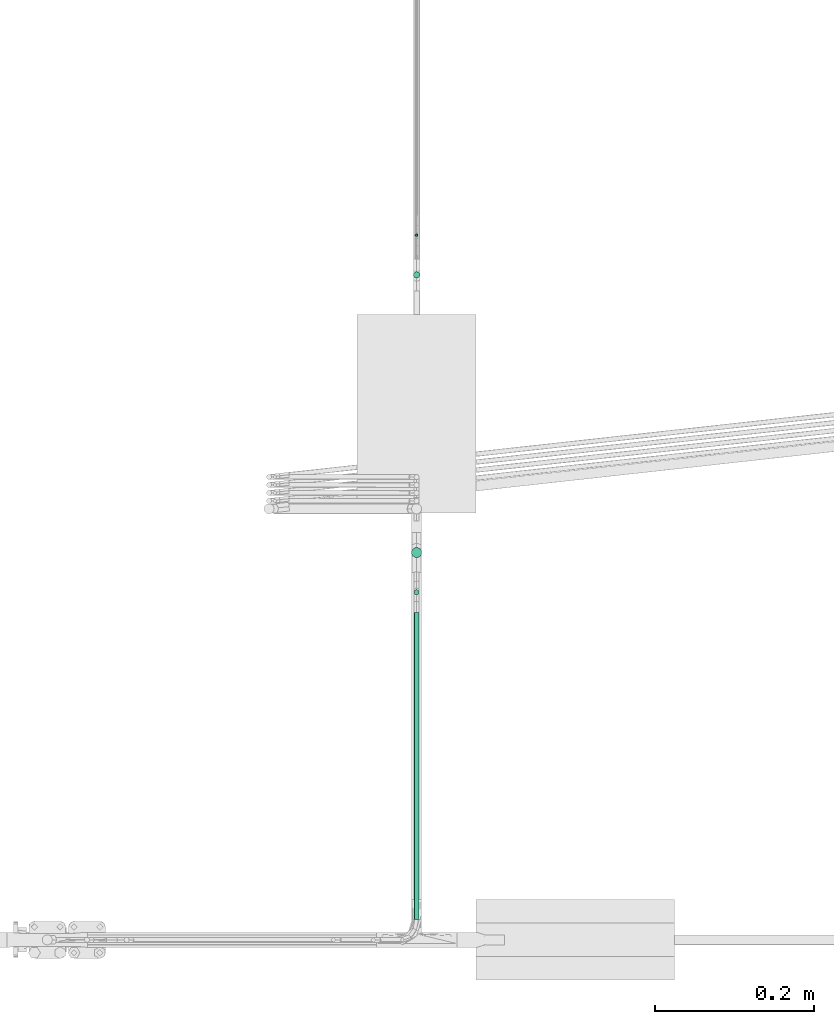
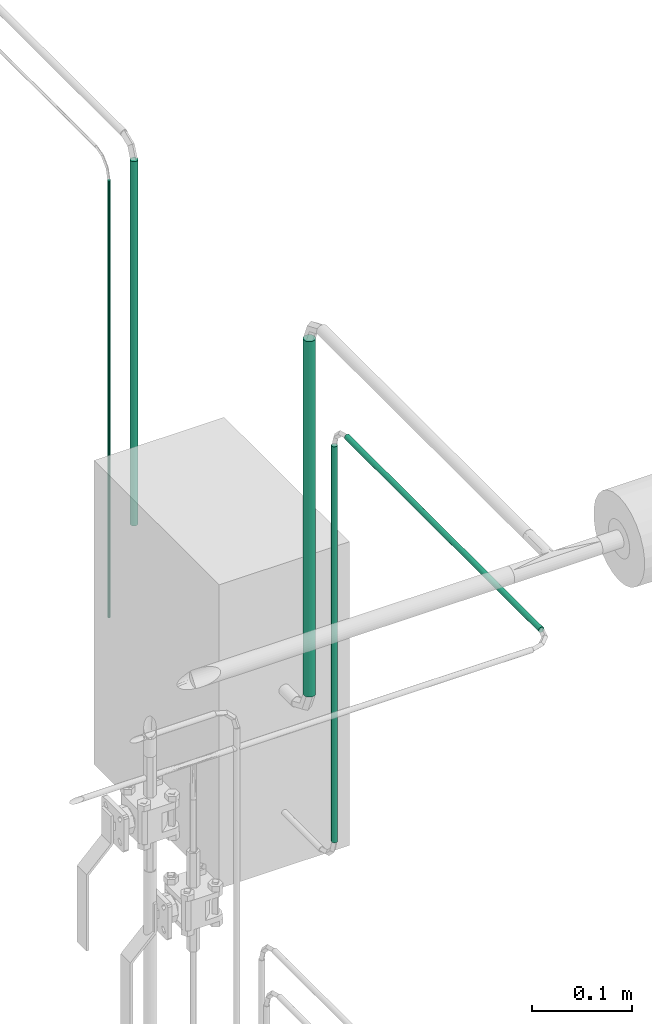
# One storey, part 9 of 45: 5 flow segments.
"""IFC2X3 building model written with IfcOpenShell, lengths in millimetres."""

from ifc_helpers import new_model, entity, si_unit, converted_unit, derived_unit, direction, frame, origin, origin_2d_with_axis, place, context, subcontext, project, spatial, circle, extrude, type_object, element, save


model = new_model("IFC2X3")

# Units and contexts
model_context = context("Model", 3, precision=0.01, world=origin(), true_north=direction((6.12303176911189e-17, 1.0)))
body_context = subcontext(model_context, "Body", "Model", "MODEL_VIEW")
ifc_project = project(units=[si_unit("LENGTHUNIT", "METRE", prefix="MILLI"), si_unit("AREAUNIT", "SQUARE_METRE"), si_unit("VOLUMEUNIT", "CUBIC_METRE"), converted_unit("PLANEANGLEUNIT", "DEGREE", entity("IfcRatioMeasure", 0.0174532925199433), si_unit("PLANEANGLEUNIT", "RADIAN"), dimensions=[0, 0, 0, 0, 0, 0, 0]), si_unit("MASSUNIT", "GRAM", prefix="KILO"), derived_unit("MASSDENSITYUNIT", [(si_unit("MASSUNIT", "GRAM", prefix="KILO"), 1), (si_unit("LENGTHUNIT", "METRE"), -3)]), derived_unit("MOMENTOFINERTIAUNIT", [(si_unit("LENGTHUNIT", "METRE"), 4)]), si_unit("TIMEUNIT", "SECOND"), si_unit("FREQUENCYUNIT", "HERTZ"), si_unit("THERMODYNAMICTEMPERATUREUNIT", "DEGREE_CELSIUS"), derived_unit("THERMALTRANSMITTANCEUNIT", [(si_unit("MASSUNIT", "GRAM", prefix="KILO"), 1), (si_unit("THERMODYNAMICTEMPERATUREUNIT", "KELVIN"), -1), (si_unit("TIMEUNIT", "SECOND"), -3)]), derived_unit("VOLUMETRICFLOWRATEUNIT", [(si_unit("LENGTHUNIT", "METRE"), 3), (si_unit("TIMEUNIT", "SECOND"), -1)]), derived_unit("MASSFLOWRATEUNIT", [(si_unit("MASSUNIT", "GRAM", prefix="KILO"), 1), (si_unit("TIMEUNIT", "SECOND"), -1)]), derived_unit("ROTATIONALFREQUENCYUNIT", [(si_unit("TIMEUNIT", "SECOND"), -1)]), si_unit("ELECTRICCURRENTUNIT", "AMPERE"), si_unit("ELECTRICVOLTAGEUNIT", "VOLT"), si_unit("POWERUNIT", "WATT"), si_unit("FORCEUNIT", "NEWTON", prefix="KILO"), si_unit("ILLUMINANCEUNIT", "LUX"), si_unit("LUMINOUSFLUXUNIT", "LUMEN"), si_unit("LUMINOUSINTENSITYUNIT", "CANDELA"), derived_unit("USERDEFINED", [(si_unit("MASSUNIT", "GRAM", prefix="KILO"), -1), (si_unit("LENGTHUNIT", "METRE"), -2), (si_unit("TIMEUNIT", "SECOND"), 3), (si_unit("LUMINOUSFLUXUNIT", "LUMEN"), 1)]), derived_unit("LINEARVELOCITYUNIT", [(si_unit("LENGTHUNIT", "METRE"), 1), (si_unit("TIMEUNIT", "SECOND"), -1)]), si_unit("PRESSUREUNIT", "PASCAL"), derived_unit("USERDEFINED", [(si_unit("LENGTHUNIT", "METRE"), -2), (si_unit("MASSUNIT", "GRAM", prefix="KILO"), 1), (si_unit("TIMEUNIT", "SECOND"), -2)]), derived_unit("LINEARFORCEUNIT", [(si_unit("MASSUNIT", "GRAM", prefix="KILO"), 1), (si_unit("LENGTHUNIT", "METRE"), 1), (si_unit("TIMEUNIT", "SECOND"), -2), (si_unit("LENGTHUNIT", "METRE"), -1)]), derived_unit("PLANARFORCEUNIT", [(si_unit("MASSUNIT", "GRAM", prefix="KILO"), 1), (si_unit("LENGTHUNIT", "METRE"), 1), (si_unit("TIMEUNIT", "SECOND"), -2), (si_unit("LENGTHUNIT", "METRE"), -2)])], contexts=[model_context])

# Site, building, storey
site_placement = place(None, frame((-24836.06, 8968.75, 0.0)))
site = spatial("IfcSite", under=ifc_project, at=site_placement, CompositionType="ELEMENT")
building_placement = place(site_placement, origin())
building = spatial("IfcBuilding", under=site, at=building_placement, CompositionType="ELEMENT")
storey_placement = place(building_placement, frame((0.0, 0.0, -4200.0)))
storey = spatial("IfcBuildingStorey", under=building, at=storey_placement, CompositionType="ELEMENT", Elevation=-4200.0)

# Flow segments
pipe_segment_type_1 = type_object("IfcPipeSegmentType", PredefinedType="NOTDEFINED")
flow_segment_1_placement = place(storey_placement, frame((69642.96, -8456.9, 1741.65)))
element("IfcFlowSegment", 1, at=flow_segment_1_placement, inside=storey, type_object=pipe_segment_type_1, context=body_context, shape_type="SweptSolid", body=[
    extrude(circle(Radius=6.35, at=origin_2d_with_axis()), frame((7.95, 7.95, 0.0)), (0.0, 0.0, 1.0), 432.950000000001),
])
flow_segment_2_placement = place(storey_placement, frame((69647.72, -8052.14, 1592.28)))
element("IfcFlowSegment", 2, at=flow_segment_2_placement, inside=storey, type_object=pipe_segment_type_1, context=body_context, shape_type="SweptSolid", body=[
    extrude(circle(Radius=1.59, at=origin_2d_with_axis()), frame((3.19, 3.19, 0.0), z_axis=(0.0, 0.0, 1.0), x_axis=(-1.0, 0.0, 0.0)), (0.0, 0.0, 1.0), 532.321892077683),
])
flow_segment_3_placement = place(storey_placement, frame((69646.14, -8503.72, 1592.28)))
element("IfcFlowSegment", 3, at=flow_segment_3_placement, inside=storey, type_object=pipe_segment_type_1, context=body_context, shape_type="SweptSolid", body=[
    extrude(circle(Radius=3.175, at=origin_2d_with_axis()), frame((4.77, 4.77, 0.0), z_axis=(0.0, 0.0, 1.0), x_axis=(-1.0, 0.0, 0.0)), (0.0, 0.0, 1.0), 482.321892077683),
])
flow_segment_4_placement = place(storey_placement, frame((69646.14, -8911.84, 2095.23)))
element("IfcFlowSegment", 4, at=flow_segment_4_placement, inside=storey, type_object=pipe_segment_type_1, context=body_context, shape_type="SweptSolid", body=[
    extrude(circle(Radius=3.175, at=origin_2d_with_axis()), frame((4.77, 0.0, 4.77), z_axis=(0.0, 1.0, 0.0), x_axis=(1.0, 0.0, 0.0)), (0.0, 0.0, 1.0), 387.493545193561),
])
pipe_segment_type_2 = type_object("IfcPipeSegmentType", PredefinedType="NOTDEFINED")
flow_segment_5_placement = place(storey_placement, frame((69645.31, -8104.55, 1736.25)))
element("IfcFlowSegment", 5, at=flow_segment_5_placement, inside=storey, type_object=pipe_segment_type_2, context=body_context, shape_type="SweptSolid", body=[
    extrude(circle(Radius=4.0, at=origin_2d_with_axis()), frame((5.6, 5.6, 0.0)), (0.0, 0.0, 1.0), 443.749999999994),
])

save(model, "model.ifc")
